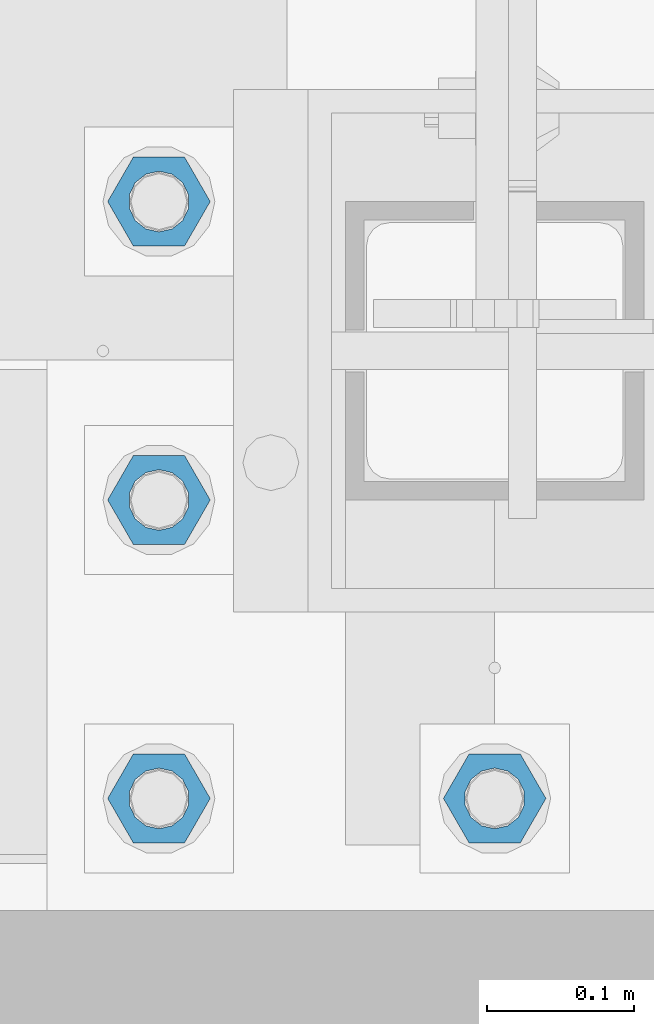
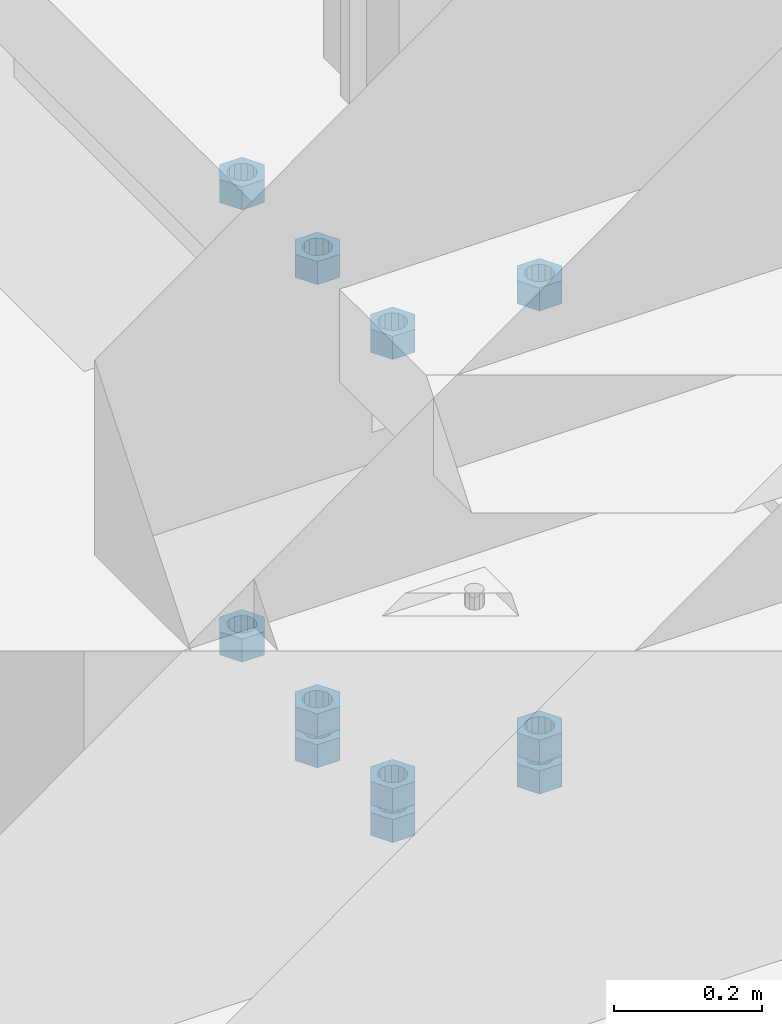
# One storey, part 978 of 1763: 11 columns, 1 element without a shape of its own.
"""IFC2X3 building model written with IfcOpenShell, lengths in millimetres."""

from ifc_helpers import new_model, si_unit, frame, origin_with_axes, place, context, subcontext, project, spatial, faceted_brep, material, type_object, element, aggregate, save


model = new_model("IFC2X3")

# Units and contexts
model_context = context("Model", 3, precision=1e-05, world=origin_with_axes())
body_context = subcontext(model_context, "Body", "Model", "MODEL_VIEW")
ifc_project = project(units=[si_unit("LENGTHUNIT", "METRE", prefix="MILLI"), si_unit("AREAUNIT", "SQUARE_METRE"), si_unit("VOLUMEUNIT", "CUBIC_METRE"), si_unit("MASSUNIT", "GRAM", prefix="KILO"), si_unit("TIMEUNIT", "SECOND"), si_unit("PLANEANGLEUNIT", "RADIAN"), si_unit("SOLIDANGLEUNIT", "STERADIAN"), si_unit("THERMODYNAMICTEMPERATUREUNIT", "DEGREE_CELSIUS"), si_unit("LUMINOUSINTENSITYUNIT", "LUMEN")], contexts=[model_context])

# Site, building, storey
site_placement = place(None, origin_with_axes())
site = spatial("IfcSite", under=ifc_project, at=site_placement, CompositionType="ELEMENT")
building_placement = place(site_placement, origin_with_axes())
building = spatial("IfcBuilding", under=site, at=building_placement, Name="Undefined", CompositionType="ELEMENT")
storey_placement = place(building_placement, origin_with_axes())
storey = spatial("IfcBuildingStorey", under=building, at=storey_placement, Name="Undefined", CompositionType="ELEMENT", Elevation=0.0)

# Assembly, columns
assembly_placement = place(storey_placement, origin_with_axes())
assembly = element("IfcElementAssembly", 1, at=assembly_placement, inside=storey, Name="TEMPLATE", AssemblyPlace="NOTDEFINED", PredefinedType="RIGID_FRAME")
ifc_material = material(Name="STEEL/A563")
column_type = type_object("IfcColumnType", Name="1-1/2_HEAVY_HEX_NUT", PredefinedType="NOTDEFINED")
column_1_placement = place(assembly_placement, frame((-87604.0372736983, -14020.8, 5189.53750000001), z_axis=(0.0, -1.0, 0.0), x_axis=(0.0, 0.0, -1.0)))
column_1 = element("IfcColumn", 2, at=column_1_placement, type_object=column_type, material=ifc_material, Name="NUT", ObjectType="1-1/2_HEAVY_HEX_NUT", context=body_context, shape_type="Brep", body=[
    faceted_brep([(0.0, -34.9199981689453, 0.0), (0.0, -17.4599990844727, -30.25), (38.1000000000004, -17.4599990844727, -30.25), (38.1000000000004, -34.9199981689453, 0.0), (0.0, 17.4599990844727, -30.25), (38.1000000000004, 17.4599990844727, -30.25), (0.0, 34.9199981689453, 0.0), (38.1000000000004, 34.9199981689453, 0.0), (0.0, 17.4599990844727, 30.25), (38.1000000000004, 17.4599990844727, 30.25), (0.0, -17.4599990844727, 30.25), (38.1000000000004, -17.4599990844727, 30.25), (0.0, 0.0, 20.6399993896484), (0.0, 8.95536011056538, 18.5959968835978), (38.1000000000004, 8.95536011056538, 18.5959968835978), (38.1000000000004, 0.0, 20.6399993896484), (0.0, 16.1370013209453, 12.8688291298167), (38.1000000000004, 16.1370013209453, 12.8688291298167), (0.0, 20.1225115123816, 4.59283194104137), (38.1000000000004, 20.1225115123816, 4.59283194104137), (0.0, 20.1225115123816, -4.59283194104319), (38.1000000000004, 20.1225115123816, -4.59283194104319), (0.0, 16.1370013209453, -12.8688291298167), (38.1000000000004, 16.1370013209453, -12.8688291298167), (0.0, 8.95536011056538, -18.5959968835978), (38.1000000000004, 8.95536011056538, -18.5959968835978), (0.0, 0.0, -20.6399993896484), (38.1000000000004, 0.0, -20.6399993896484), (0.0, -8.95536011056538, -18.5959968835978), (38.1000000000004, -8.95536011056538, -18.5959968835978), (0.0, -16.1370013209453, -12.8688291298167), (38.1000000000004, -16.1370013209453, -12.8688291298167), (0.0, -20.1225115123816, -4.59283194104137), (38.1000000000004, -20.1225115123816, -4.59283194104137), (0.0, -20.1225115123816, 4.59283194104319), (38.1000000000004, -20.1225115123816, 4.59283194104319), (0.0, -16.1370013209453, 12.8688291298167), (38.1000000000004, -16.1370013209453, 12.8688291298167), (0.0, -8.95536011056538, 18.5959968835978), (38.1000000000004, -8.95536011056538, 18.5959968835978)], [[[0, 1, 2, 3]], [[1, 4, 5, 2]], [[4, 6, 7, 5]], [[6, 8, 9, 7]], [[8, 10, 11, 9]], [[10, 0, 3, 11]], [[12, 13, 14, 15]], [[13, 16, 17, 14]], [[16, 18, 19, 17]], [[18, 20, 21, 19]], [[20, 22, 23, 21]], [[22, 24, 25, 23]], [[24, 26, 27, 25]], [[26, 28, 29, 27]], [[28, 30, 31, 29]], [[30, 32, 33, 31]], [[32, 34, 35, 33]], [[34, 36, 37, 35]], [[36, 38, 39, 37]], [[38, 12, 15, 39]], [[5, 7, 9, 11, 3, 2], [17, 19, 21, 23, 25, 27, 29, 31, 33, 35, 37, 39, 15, 14]], [[10, 8, 6, 4, 1, 0], [38, 36, 34, 32, 30, 28, 26, 24, 22, 20, 18, 16, 13, 12]]]),
])
column_2_placement = place(assembly_placement, frame((-87604.0372736983, -14020.8, 4445.00000000001), z_axis=(0.0, -1.0, 0.0), x_axis=(0.0, 0.0, -1.0)))
column_2 = element("IfcColumn", 3, at=column_2_placement, type_object=column_type, material=ifc_material, Name="NUT", ObjectType="1-1/2_HEAVY_HEX_NUT", context=body_context, shape_type="Brep", body=[
    faceted_brep([(0.0, -34.9199981689453, 0.0), (0.0, -17.4599990844727, -30.25), (38.1000000000004, -17.4599990844727, -30.25), (38.1000000000004, -34.9199981689453, 0.0), (0.0, 17.4599990844727, -30.25), (38.1000000000004, 17.4599990844727, -30.25), (0.0, 34.9199981689453, 0.0), (38.1000000000004, 34.9199981689453, 0.0), (0.0, 17.4599990844727, 30.25), (38.1000000000004, 17.4599990844727, 30.25), (0.0, -17.4599990844727, 30.25), (38.1000000000004, -17.4599990844727, 30.25), (0.0, 0.0, 20.6399993896484), (0.0, 8.95536011056538, 18.5959968835978), (38.1000000000004, 8.95536011056538, 18.5959968835978), (38.1000000000004, 0.0, 20.6399993896484), (0.0, 16.1370013209453, 12.8688291298167), (38.1000000000004, 16.1370013209453, 12.8688291298167), (0.0, 20.1225115123816, 4.59283194104137), (38.1000000000004, 20.1225115123816, 4.59283194104137), (0.0, 20.1225115123816, -4.59283194104319), (38.1000000000004, 20.1225115123816, -4.59283194104319), (0.0, 16.1370013209453, -12.8688291298167), (38.1000000000004, 16.1370013209453, -12.8688291298167), (0.0, 8.95536011056538, -18.5959968835978), (38.1000000000004, 8.95536011056538, -18.5959968835978), (0.0, 0.0, -20.6399993896484), (38.1000000000004, 0.0, -20.6399993896484), (0.0, -8.95536011056538, -18.5959968835978), (38.1000000000004, -8.95536011056538, -18.5959968835978), (0.0, -16.1370013209453, -12.8688291298167), (38.1000000000004, -16.1370013209453, -12.8688291298167), (0.0, -20.1225115123816, -4.59283194104137), (38.1000000000004, -20.1225115123816, -4.59283194104137), (0.0, -20.1225115123816, 4.59283194104319), (38.1000000000004, -20.1225115123816, 4.59283194104319), (0.0, -16.1370013209453, 12.8688291298167), (38.1000000000004, -16.1370013209453, 12.8688291298167), (0.0, -8.95536011056538, 18.5959968835978), (38.1000000000004, -8.95536011056538, 18.5959968835978)], [[[0, 1, 2, 3]], [[1, 4, 5, 2]], [[4, 6, 7, 5]], [[6, 8, 9, 7]], [[8, 10, 11, 9]], [[10, 0, 3, 11]], [[12, 13, 14, 15]], [[13, 16, 17, 14]], [[16, 18, 19, 17]], [[18, 20, 21, 19]], [[20, 22, 23, 21]], [[22, 24, 25, 23]], [[24, 26, 27, 25]], [[26, 28, 29, 27]], [[28, 30, 31, 29]], [[30, 32, 33, 31]], [[32, 34, 35, 33]], [[34, 36, 37, 35]], [[36, 38, 39, 37]], [[38, 12, 15, 39]], [[5, 7, 9, 11, 3, 2], [17, 19, 21, 23, 25, 27, 29, 31, 33, 35, 37, 39, 15, 14]], [[10, 8, 6, 4, 1, 0], [38, 36, 34, 32, 30, 28, 26, 24, 22, 20, 18, 16, 13, 12]]]),
])
column_3_placement = place(assembly_placement, frame((-87604.0372736983, -14020.8, 4394.20000000001), z_axis=(0.0, -1.0, 0.0), x_axis=(0.0, 0.0, -1.0)))
column_3 = element("IfcColumn", 4, at=column_3_placement, type_object=column_type, material=ifc_material, Name="NUT", ObjectType="1-1/2_HEAVY_HEX_NUT", context=body_context, shape_type="Brep", body=[
    faceted_brep([(0.0, -34.9199981689453, 0.0), (0.0, -17.4599990844727, -30.25), (38.1000000000004, -17.4599990844727, -30.25), (38.1000000000004, -34.9199981689453, 0.0), (0.0, 17.4599990844727, -30.25), (38.1000000000004, 17.4599990844727, -30.25), (0.0, 34.9199981689453, 0.0), (38.1000000000004, 34.9199981689453, 0.0), (0.0, 17.4599990844727, 30.25), (38.1000000000004, 17.4599990844727, 30.25), (0.0, -17.4599990844727, 30.25), (38.1000000000004, -17.4599990844727, 30.25), (0.0, 0.0, 20.6399993896484), (0.0, 8.95536011056538, 18.5959968835978), (38.1000000000004, 8.95536011056538, 18.5959968835978), (38.1000000000004, 0.0, 20.6399993896484), (0.0, 16.1370013209453, 12.8688291298167), (38.1000000000004, 16.1370013209453, 12.8688291298167), (0.0, 20.1225115123816, 4.59283194104137), (38.1000000000004, 20.1225115123816, 4.59283194104137), (0.0, 20.1225115123816, -4.59283194104319), (38.1000000000004, 20.1225115123816, -4.59283194104319), (0.0, 16.1370013209453, -12.8688291298167), (38.1000000000004, 16.1370013209453, -12.8688291298167), (0.0, 8.95536011056538, -18.5959968835978), (38.1000000000004, 8.95536011056538, -18.5959968835978), (0.0, 0.0, -20.6399993896484), (38.1000000000004, 0.0, -20.6399993896484), (0.0, -8.95536011056538, -18.5959968835978), (38.1000000000004, -8.95536011056538, -18.5959968835978), (0.0, -16.1370013209453, -12.8688291298167), (38.1000000000004, -16.1370013209453, -12.8688291298167), (0.0, -20.1225115123816, -4.59283194104137), (38.1000000000004, -20.1225115123816, -4.59283194104137), (0.0, -20.1225115123816, 4.59283194104319), (38.1000000000004, -20.1225115123816, 4.59283194104319), (0.0, -16.1370013209453, 12.8688291298167), (38.1000000000004, -16.1370013209453, 12.8688291298167), (0.0, -8.95536011056538, 18.5959968835978), (38.1000000000004, -8.95536011056538, 18.5959968835978)], [[[0, 1, 2, 3]], [[1, 4, 5, 2]], [[4, 6, 7, 5]], [[6, 8, 9, 7]], [[8, 10, 11, 9]], [[10, 0, 3, 11]], [[12, 13, 14, 15]], [[13, 16, 17, 14]], [[16, 18, 19, 17]], [[18, 20, 21, 19]], [[20, 22, 23, 21]], [[22, 24, 25, 23]], [[24, 26, 27, 25]], [[26, 28, 29, 27]], [[28, 30, 31, 29]], [[30, 32, 33, 31]], [[32, 34, 35, 33]], [[34, 36, 37, 35]], [[36, 38, 39, 37]], [[38, 12, 15, 39]], [[5, 7, 9, 11, 3, 2], [17, 19, 21, 23, 25, 27, 29, 31, 33, 35, 37, 39, 15, 14]], [[10, 8, 6, 4, 1, 0], [38, 36, 34, 32, 30, 28, 26, 24, 22, 20, 18, 16, 13, 12]]]),
])
column_4_placement = place(assembly_placement, frame((-87375.4372736983, -14020.8, 5189.53750000001), z_axis=(0.0, -1.0, 0.0), x_axis=(0.0, 0.0, -1.0)))
column_4 = element("IfcColumn", 5, at=column_4_placement, type_object=column_type, material=ifc_material, Name="NUT", ObjectType="1-1/2_HEAVY_HEX_NUT", context=body_context, shape_type="Brep", body=[
    faceted_brep([(0.0, -34.9199981689453, 0.0), (0.0, -17.4599990844727, -30.25), (38.1000000000004, -17.4599990844727, -30.25), (38.1000000000004, -34.9199981689453, 0.0), (0.0, 17.4599990844727, -30.25), (38.1000000000004, 17.4599990844727, -30.25), (0.0, 34.9199981689453, 0.0), (38.1000000000004, 34.9199981689453, 0.0), (0.0, 17.4599990844727, 30.25), (38.1000000000004, 17.4599990844727, 30.25), (0.0, -17.4599990844727, 30.25), (38.1000000000004, -17.4599990844727, 30.25), (0.0, 0.0, 20.6399993896484), (0.0, 8.95536011056538, 18.5959968835978), (38.1000000000004, 8.95536011056538, 18.5959968835978), (38.1000000000004, 0.0, 20.6399993896484), (0.0, 16.1370013209453, 12.8688291298167), (38.1000000000004, 16.1370013209453, 12.8688291298167), (0.0, 20.1225115123816, 4.59283194104137), (38.1000000000004, 20.1225115123816, 4.59283194104137), (0.0, 20.1225115123816, -4.59283194104319), (38.1000000000004, 20.1225115123816, -4.59283194104319), (0.0, 16.1370013209453, -12.8688291298167), (38.1000000000004, 16.1370013209453, -12.8688291298167), (0.0, 8.95536011056538, -18.5959968835978), (38.1000000000004, 8.95536011056538, -18.5959968835978), (0.0, 0.0, -20.6399993896484), (38.1000000000004, 0.0, -20.6399993896484), (0.0, -8.95536011056538, -18.5959968835978), (38.1000000000004, -8.95536011056538, -18.5959968835978), (0.0, -16.1370013209453, -12.8688291298167), (38.1000000000004, -16.1370013209453, -12.8688291298167), (0.0, -20.1225115123816, -4.59283194104137), (38.1000000000004, -20.1225115123816, -4.59283194104137), (0.0, -20.1225115123816, 4.59283194104319), (38.1000000000004, -20.1225115123816, 4.59283194104319), (0.0, -16.1370013209453, 12.8688291298167), (38.1000000000004, -16.1370013209453, 12.8688291298167), (0.0, -8.95536011056538, 18.5959968835978), (38.1000000000004, -8.95536011056538, 18.5959968835978)], [[[0, 1, 2, 3]], [[1, 4, 5, 2]], [[4, 6, 7, 5]], [[6, 8, 9, 7]], [[8, 10, 11, 9]], [[10, 0, 3, 11]], [[12, 13, 14, 15]], [[13, 16, 17, 14]], [[16, 18, 19, 17]], [[18, 20, 21, 19]], [[20, 22, 23, 21]], [[22, 24, 25, 23]], [[24, 26, 27, 25]], [[26, 28, 29, 27]], [[28, 30, 31, 29]], [[30, 32, 33, 31]], [[32, 34, 35, 33]], [[34, 36, 37, 35]], [[36, 38, 39, 37]], [[38, 12, 15, 39]], [[5, 7, 9, 11, 3, 2], [17, 19, 21, 23, 25, 27, 29, 31, 33, 35, 37, 39, 15, 14]], [[10, 8, 6, 4, 1, 0], [38, 36, 34, 32, 30, 28, 26, 24, 22, 20, 18, 16, 13, 12]]]),
])
column_5_placement = place(assembly_placement, frame((-87375.4372736983, -14020.8, 4445.00000000001), z_axis=(0.0, -1.0, 0.0), x_axis=(0.0, 0.0, -1.0)))
column_5 = element("IfcColumn", 6, at=column_5_placement, type_object=column_type, material=ifc_material, Name="NUT", ObjectType="1-1/2_HEAVY_HEX_NUT", context=body_context, shape_type="Brep", body=[
    faceted_brep([(0.0, -34.9199981689453, 0.0), (0.0, -17.4599990844727, -30.25), (38.1000000000004, -17.4599990844727, -30.25), (38.1000000000004, -34.9199981689453, 0.0), (0.0, 17.4599990844727, -30.25), (38.1000000000004, 17.4599990844727, -30.25), (0.0, 34.9199981689453, 0.0), (38.1000000000004, 34.9199981689453, 0.0), (0.0, 17.4599990844727, 30.25), (38.1000000000004, 17.4599990844727, 30.25), (0.0, -17.4599990844727, 30.25), (38.1000000000004, -17.4599990844727, 30.25), (0.0, 0.0, 20.6399993896484), (0.0, 8.95536011056538, 18.5959968835978), (38.1000000000004, 8.95536011056538, 18.5959968835978), (38.1000000000004, 0.0, 20.6399993896484), (0.0, 16.1370013209453, 12.8688291298167), (38.1000000000004, 16.1370013209453, 12.8688291298167), (0.0, 20.1225115123816, 4.59283194104137), (38.1000000000004, 20.1225115123816, 4.59283194104137), (0.0, 20.1225115123816, -4.59283194104319), (38.1000000000004, 20.1225115123816, -4.59283194104319), (0.0, 16.1370013209453, -12.8688291298167), (38.1000000000004, 16.1370013209453, -12.8688291298167), (0.0, 8.95536011056538, -18.5959968835978), (38.1000000000004, 8.95536011056538, -18.5959968835978), (0.0, 0.0, -20.6399993896484), (38.1000000000004, 0.0, -20.6399993896484), (0.0, -8.95536011056538, -18.5959968835978), (38.1000000000004, -8.95536011056538, -18.5959968835978), (0.0, -16.1370013209453, -12.8688291298167), (38.1000000000004, -16.1370013209453, -12.8688291298167), (0.0, -20.1225115123816, -4.59283194104137), (38.1000000000004, -20.1225115123816, -4.59283194104137), (0.0, -20.1225115123816, 4.59283194104319), (38.1000000000004, -20.1225115123816, 4.59283194104319), (0.0, -16.1370013209453, 12.8688291298167), (38.1000000000004, -16.1370013209453, 12.8688291298167), (0.0, -8.95536011056538, 18.5959968835978), (38.1000000000004, -8.95536011056538, 18.5959968835978)], [[[0, 1, 2, 3]], [[1, 4, 5, 2]], [[4, 6, 7, 5]], [[6, 8, 9, 7]], [[8, 10, 11, 9]], [[10, 0, 3, 11]], [[12, 13, 14, 15]], [[13, 16, 17, 14]], [[16, 18, 19, 17]], [[18, 20, 21, 19]], [[20, 22, 23, 21]], [[22, 24, 25, 23]], [[24, 26, 27, 25]], [[26, 28, 29, 27]], [[28, 30, 31, 29]], [[30, 32, 33, 31]], [[32, 34, 35, 33]], [[34, 36, 37, 35]], [[36, 38, 39, 37]], [[38, 12, 15, 39]], [[5, 7, 9, 11, 3, 2], [17, 19, 21, 23, 25, 27, 29, 31, 33, 35, 37, 39, 15, 14]], [[10, 8, 6, 4, 1, 0], [38, 36, 34, 32, 30, 28, 26, 24, 22, 20, 18, 16, 13, 12]]]),
])
column_6_placement = place(assembly_placement, frame((-87375.4372736983, -14020.8, 4394.20000000001), z_axis=(0.0, -1.0, 0.0), x_axis=(0.0, 0.0, -1.0)))
column_6 = element("IfcColumn", 7, at=column_6_placement, type_object=column_type, material=ifc_material, Name="NUT", ObjectType="1-1/2_HEAVY_HEX_NUT", context=body_context, shape_type="Brep", body=[
    faceted_brep([(0.0, -34.9199981689453, 0.0), (0.0, -17.4599990844727, -30.25), (38.1000000000004, -17.4599990844727, -30.25), (38.1000000000004, -34.9199981689453, 0.0), (0.0, 17.4599990844727, -30.25), (38.1000000000004, 17.4599990844727, -30.25), (0.0, 34.9199981689453, 0.0), (38.1000000000004, 34.9199981689453, 0.0), (0.0, 17.4599990844727, 30.25), (38.1000000000004, 17.4599990844727, 30.25), (0.0, -17.4599990844727, 30.25), (38.1000000000004, -17.4599990844727, 30.25), (0.0, 0.0, 20.6399993896484), (0.0, 8.95536011056538, 18.5959968835978), (38.1000000000004, 8.95536011056538, 18.5959968835978), (38.1000000000004, 0.0, 20.6399993896484), (0.0, 16.1370013209453, 12.8688291298167), (38.1000000000004, 16.1370013209453, 12.8688291298167), (0.0, 20.1225115123816, 4.59283194104137), (38.1000000000004, 20.1225115123816, 4.59283194104137), (0.0, 20.1225115123816, -4.59283194104319), (38.1000000000004, 20.1225115123816, -4.59283194104319), (0.0, 16.1370013209453, -12.8688291298167), (38.1000000000004, 16.1370013209453, -12.8688291298167), (0.0, 8.95536011056538, -18.5959968835978), (38.1000000000004, 8.95536011056538, -18.5959968835978), (0.0, 0.0, -20.6399993896484), (38.1000000000004, 0.0, -20.6399993896484), (0.0, -8.95536011056538, -18.5959968835978), (38.1000000000004, -8.95536011056538, -18.5959968835978), (0.0, -16.1370013209453, -12.8688291298167), (38.1000000000004, -16.1370013209453, -12.8688291298167), (0.0, -20.1225115123816, -4.59283194104137), (38.1000000000004, -20.1225115123816, -4.59283194104137), (0.0, -20.1225115123816, 4.59283194104319), (38.1000000000004, -20.1225115123816, 4.59283194104319), (0.0, -16.1370013209453, 12.8688291298167), (38.1000000000004, -16.1370013209453, 12.8688291298167), (0.0, -8.95536011056538, 18.5959968835978), (38.1000000000004, -8.95536011056538, 18.5959968835978)], [[[0, 1, 2, 3]], [[1, 4, 5, 2]], [[4, 6, 7, 5]], [[6, 8, 9, 7]], [[8, 10, 11, 9]], [[10, 0, 3, 11]], [[12, 13, 14, 15]], [[13, 16, 17, 14]], [[16, 18, 19, 17]], [[18, 20, 21, 19]], [[20, 22, 23, 21]], [[22, 24, 25, 23]], [[24, 26, 27, 25]], [[26, 28, 29, 27]], [[28, 30, 31, 29]], [[30, 32, 33, 31]], [[32, 34, 35, 33]], [[34, 36, 37, 35]], [[36, 38, 39, 37]], [[38, 12, 15, 39]], [[5, 7, 9, 11, 3, 2], [17, 19, 21, 23, 25, 27, 29, 31, 33, 35, 37, 39, 15, 14]], [[10, 8, 6, 4, 1, 0], [38, 36, 34, 32, 30, 28, 26, 24, 22, 20, 18, 16, 13, 12]]]),
])
column_7_placement = place(assembly_placement, frame((-87604.0372736983, -13817.6, 5189.53750000001), z_axis=(0.0, -1.0, 0.0), x_axis=(0.0, 0.0, -1.0)))
column_7 = element("IfcColumn", 8, at=column_7_placement, type_object=column_type, material=ifc_material, Name="NUT", ObjectType="1-1/2_HEAVY_HEX_NUT", context=body_context, shape_type="Brep", body=[
    faceted_brep([(0.0, -34.9199981689453, 0.0), (0.0, -17.4599990844727, -30.25), (38.1000000000004, -17.4599990844727, -30.25), (38.1000000000004, -34.9199981689453, 0.0), (0.0, 17.4599990844727, -30.25), (38.1000000000004, 17.4599990844727, -30.25), (0.0, 34.9199981689453, 0.0), (38.1000000000004, 34.9199981689453, 0.0), (0.0, 17.4599990844727, 30.25), (38.1000000000004, 17.4599990844727, 30.25), (0.0, -17.4599990844727, 30.25), (38.1000000000004, -17.4599990844727, 30.25), (0.0, 0.0, 20.6399993896484), (0.0, 8.95536011056538, 18.5959968835978), (38.1000000000004, 8.95536011056538, 18.5959968835978), (38.1000000000004, 0.0, 20.6399993896484), (0.0, 16.1370013209453, 12.8688291298167), (38.1000000000004, 16.1370013209453, 12.8688291298167), (0.0, 20.1225115123816, 4.59283194104137), (38.1000000000004, 20.1225115123816, 4.59283194104137), (0.0, 20.1225115123816, -4.59283194104319), (38.1000000000004, 20.1225115123816, -4.59283194104319), (0.0, 16.1370013209453, -12.8688291298167), (38.1000000000004, 16.1370013209453, -12.8688291298167), (0.0, 8.95536011056538, -18.5959968835978), (38.1000000000004, 8.95536011056538, -18.5959968835978), (0.0, 0.0, -20.6399993896484), (38.1000000000004, 0.0, -20.6399993896484), (0.0, -8.95536011056538, -18.5959968835978), (38.1000000000004, -8.95536011056538, -18.5959968835978), (0.0, -16.1370013209453, -12.8688291298167), (38.1000000000004, -16.1370013209453, -12.8688291298167), (0.0, -20.1225115123816, -4.59283194104137), (38.1000000000004, -20.1225115123816, -4.59283194104137), (0.0, -20.1225115123816, 4.59283194104319), (38.1000000000004, -20.1225115123816, 4.59283194104319), (0.0, -16.1370013209453, 12.8688291298167), (38.1000000000004, -16.1370013209453, 12.8688291298167), (0.0, -8.95536011056538, 18.5959968835978), (38.1000000000004, -8.95536011056538, 18.5959968835978)], [[[0, 1, 2, 3]], [[1, 4, 5, 2]], [[4, 6, 7, 5]], [[6, 8, 9, 7]], [[8, 10, 11, 9]], [[10, 0, 3, 11]], [[12, 13, 14, 15]], [[13, 16, 17, 14]], [[16, 18, 19, 17]], [[18, 20, 21, 19]], [[20, 22, 23, 21]], [[22, 24, 25, 23]], [[24, 26, 27, 25]], [[26, 28, 29, 27]], [[28, 30, 31, 29]], [[30, 32, 33, 31]], [[32, 34, 35, 33]], [[34, 36, 37, 35]], [[36, 38, 39, 37]], [[38, 12, 15, 39]], [[5, 7, 9, 11, 3, 2], [17, 19, 21, 23, 25, 27, 29, 31, 33, 35, 37, 39, 15, 14]], [[10, 8, 6, 4, 1, 0], [38, 36, 34, 32, 30, 28, 26, 24, 22, 20, 18, 16, 13, 12]]]),
])
column_8_placement = place(assembly_placement, frame((-87604.0372736983, -13817.6, 4445.00000000001), z_axis=(0.0, -1.0, 0.0), x_axis=(0.0, 0.0, -1.0)))
column_8 = element("IfcColumn", 9, at=column_8_placement, type_object=column_type, material=ifc_material, Name="NUT", ObjectType="1-1/2_HEAVY_HEX_NUT", context=body_context, shape_type="Brep", body=[
    faceted_brep([(0.0, -34.9199981689453, 0.0), (0.0, -17.4599990844727, -30.25), (38.1000000000004, -17.4599990844727, -30.25), (38.1000000000004, -34.9199981689453, 0.0), (0.0, 17.4599990844727, -30.25), (38.1000000000004, 17.4599990844727, -30.25), (0.0, 34.9199981689453, 0.0), (38.1000000000004, 34.9199981689453, 0.0), (0.0, 17.4599990844727, 30.25), (38.1000000000004, 17.4599990844727, 30.25), (0.0, -17.4599990844727, 30.25), (38.1000000000004, -17.4599990844727, 30.25), (0.0, 0.0, 20.6399993896484), (0.0, 8.95536011056538, 18.5959968835978), (38.1000000000004, 8.95536011056538, 18.5959968835978), (38.1000000000004, 0.0, 20.6399993896484), (0.0, 16.1370013209453, 12.8688291298167), (38.1000000000004, 16.1370013209453, 12.8688291298167), (0.0, 20.1225115123816, 4.59283194104137), (38.1000000000004, 20.1225115123816, 4.59283194104137), (0.0, 20.1225115123816, -4.59283194104319), (38.1000000000004, 20.1225115123816, -4.59283194104319), (0.0, 16.1370013209453, -12.8688291298167), (38.1000000000004, 16.1370013209453, -12.8688291298167), (0.0, 8.95536011056538, -18.5959968835978), (38.1000000000004, 8.95536011056538, -18.5959968835978), (0.0, 0.0, -20.6399993896484), (38.1000000000004, 0.0, -20.6399993896484), (0.0, -8.95536011056538, -18.5959968835978), (38.1000000000004, -8.95536011056538, -18.5959968835978), (0.0, -16.1370013209453, -12.8688291298167), (38.1000000000004, -16.1370013209453, -12.8688291298167), (0.0, -20.1225115123816, -4.59283194104137), (38.1000000000004, -20.1225115123816, -4.59283194104137), (0.0, -20.1225115123816, 4.59283194104319), (38.1000000000004, -20.1225115123816, 4.59283194104319), (0.0, -16.1370013209453, 12.8688291298167), (38.1000000000004, -16.1370013209453, 12.8688291298167), (0.0, -8.95536011056538, 18.5959968835978), (38.1000000000004, -8.95536011056538, 18.5959968835978)], [[[0, 1, 2, 3]], [[1, 4, 5, 2]], [[4, 6, 7, 5]], [[6, 8, 9, 7]], [[8, 10, 11, 9]], [[10, 0, 3, 11]], [[12, 13, 14, 15]], [[13, 16, 17, 14]], [[16, 18, 19, 17]], [[18, 20, 21, 19]], [[20, 22, 23, 21]], [[22, 24, 25, 23]], [[24, 26, 27, 25]], [[26, 28, 29, 27]], [[28, 30, 31, 29]], [[30, 32, 33, 31]], [[32, 34, 35, 33]], [[34, 36, 37, 35]], [[36, 38, 39, 37]], [[38, 12, 15, 39]], [[5, 7, 9, 11, 3, 2], [17, 19, 21, 23, 25, 27, 29, 31, 33, 35, 37, 39, 15, 14]], [[10, 8, 6, 4, 1, 0], [38, 36, 34, 32, 30, 28, 26, 24, 22, 20, 18, 16, 13, 12]]]),
])
column_9_placement = place(assembly_placement, frame((-87604.0372736983, -13817.6, 4394.20000000001), z_axis=(0.0, -1.0, 0.0), x_axis=(0.0, 0.0, -1.0)))
column_9 = element("IfcColumn", 10, at=column_9_placement, type_object=column_type, material=ifc_material, Name="NUT", ObjectType="1-1/2_HEAVY_HEX_NUT", context=body_context, shape_type="Brep", body=[
    faceted_brep([(0.0, -34.9199981689453, 0.0), (0.0, -17.4599990844727, -30.25), (38.1000000000004, -17.4599990844727, -30.25), (38.1000000000004, -34.9199981689453, 0.0), (0.0, 17.4599990844727, -30.25), (38.1000000000004, 17.4599990844727, -30.25), (0.0, 34.9199981689453, 0.0), (38.1000000000004, 34.9199981689453, 0.0), (0.0, 17.4599990844727, 30.25), (38.1000000000004, 17.4599990844727, 30.25), (0.0, -17.4599990844727, 30.25), (38.1000000000004, -17.4599990844727, 30.25), (0.0, 0.0, 20.6399993896484), (0.0, 8.95536011056538, 18.5959968835978), (38.1000000000004, 8.95536011056538, 18.5959968835978), (38.1000000000004, 0.0, 20.6399993896484), (0.0, 16.1370013209453, 12.8688291298167), (38.1000000000004, 16.1370013209453, 12.8688291298167), (0.0, 20.1225115123816, 4.59283194104137), (38.1000000000004, 20.1225115123816, 4.59283194104137), (0.0, 20.1225115123816, -4.59283194104319), (38.1000000000004, 20.1225115123816, -4.59283194104319), (0.0, 16.1370013209453, -12.8688291298167), (38.1000000000004, 16.1370013209453, -12.8688291298167), (0.0, 8.95536011056538, -18.5959968835978), (38.1000000000004, 8.95536011056538, -18.5959968835978), (0.0, 0.0, -20.6399993896484), (38.1000000000004, 0.0, -20.6399993896484), (0.0, -8.95536011056538, -18.5959968835978), (38.1000000000004, -8.95536011056538, -18.5959968835978), (0.0, -16.1370013209453, -12.8688291298167), (38.1000000000004, -16.1370013209453, -12.8688291298167), (0.0, -20.1225115123816, -4.59283194104137), (38.1000000000004, -20.1225115123816, -4.59283194104137), (0.0, -20.1225115123816, 4.59283194104319), (38.1000000000004, -20.1225115123816, 4.59283194104319), (0.0, -16.1370013209453, 12.8688291298167), (38.1000000000004, -16.1370013209453, 12.8688291298167), (0.0, -8.95536011056538, 18.5959968835978), (38.1000000000004, -8.95536011056538, 18.5959968835978)], [[[0, 1, 2, 3]], [[1, 4, 5, 2]], [[4, 6, 7, 5]], [[6, 8, 9, 7]], [[8, 10, 11, 9]], [[10, 0, 3, 11]], [[12, 13, 14, 15]], [[13, 16, 17, 14]], [[16, 18, 19, 17]], [[18, 20, 21, 19]], [[20, 22, 23, 21]], [[22, 24, 25, 23]], [[24, 26, 27, 25]], [[26, 28, 29, 27]], [[28, 30, 31, 29]], [[30, 32, 33, 31]], [[32, 34, 35, 33]], [[34, 36, 37, 35]], [[36, 38, 39, 37]], [[38, 12, 15, 39]], [[5, 7, 9, 11, 3, 2], [17, 19, 21, 23, 25, 27, 29, 31, 33, 35, 37, 39, 15, 14]], [[10, 8, 6, 4, 1, 0], [38, 36, 34, 32, 30, 28, 26, 24, 22, 20, 18, 16, 13, 12]]]),
])
column_10_placement = place(assembly_placement, frame((-87604.0372736983, -13614.4, 5189.53750000001), z_axis=(0.0, -1.0, 0.0), x_axis=(0.0, 0.0, -1.0)))
column_10 = element("IfcColumn", 11, at=column_10_placement, type_object=column_type, material=ifc_material, Name="NUT", ObjectType="1-1/2_HEAVY_HEX_NUT", context=body_context, shape_type="Brep", body=[
    faceted_brep([(0.0, -34.9199981689453, 0.0), (0.0, -17.4599990844727, -30.25), (38.1000000000004, -17.4599990844727, -30.25), (38.1000000000004, -34.9199981689453, 0.0), (0.0, 17.4599990844727, -30.25), (38.1000000000004, 17.4599990844727, -30.25), (0.0, 34.9199981689453, 0.0), (38.1000000000004, 34.9199981689453, 0.0), (0.0, 17.4599990844727, 30.25), (38.1000000000004, 17.4599990844727, 30.25), (0.0, -17.4599990844727, 30.25), (38.1000000000004, -17.4599990844727, 30.25), (0.0, 0.0, 20.6399993896484), (0.0, 8.95536011056538, 18.5959968835978), (38.1000000000004, 8.95536011056538, 18.5959968835978), (38.1000000000004, 0.0, 20.6399993896484), (0.0, 16.1370013209453, 12.8688291298167), (38.1000000000004, 16.1370013209453, 12.8688291298167), (0.0, 20.1225115123816, 4.59283194104137), (38.1000000000004, 20.1225115123816, 4.59283194104137), (0.0, 20.1225115123816, -4.59283194104319), (38.1000000000004, 20.1225115123816, -4.59283194104319), (0.0, 16.1370013209453, -12.8688291298167), (38.1000000000004, 16.1370013209453, -12.8688291298167), (0.0, 8.95536011056538, -18.5959968835978), (38.1000000000004, 8.95536011056538, -18.5959968835978), (0.0, 0.0, -20.6399993896484), (38.1000000000004, 0.0, -20.6399993896484), (0.0, -8.95536011056538, -18.5959968835978), (38.1000000000004, -8.95536011056538, -18.5959968835978), (0.0, -16.1370013209453, -12.8688291298167), (38.1000000000004, -16.1370013209453, -12.8688291298167), (0.0, -20.1225115123816, -4.59283194104137), (38.1000000000004, -20.1225115123816, -4.59283194104137), (0.0, -20.1225115123816, 4.59283194104319), (38.1000000000004, -20.1225115123816, 4.59283194104319), (0.0, -16.1370013209453, 12.8688291298167), (38.1000000000004, -16.1370013209453, 12.8688291298167), (0.0, -8.95536011056538, 18.5959968835978), (38.1000000000004, -8.95536011056538, 18.5959968835978)], [[[0, 1, 2, 3]], [[1, 4, 5, 2]], [[4, 6, 7, 5]], [[6, 8, 9, 7]], [[8, 10, 11, 9]], [[10, 0, 3, 11]], [[12, 13, 14, 15]], [[13, 16, 17, 14]], [[16, 18, 19, 17]], [[18, 20, 21, 19]], [[20, 22, 23, 21]], [[22, 24, 25, 23]], [[24, 26, 27, 25]], [[26, 28, 29, 27]], [[28, 30, 31, 29]], [[30, 32, 33, 31]], [[32, 34, 35, 33]], [[34, 36, 37, 35]], [[36, 38, 39, 37]], [[38, 12, 15, 39]], [[5, 7, 9, 11, 3, 2], [17, 19, 21, 23, 25, 27, 29, 31, 33, 35, 37, 39, 15, 14]], [[10, 8, 6, 4, 1, 0], [38, 36, 34, 32, 30, 28, 26, 24, 22, 20, 18, 16, 13, 12]]]),
])
column_11_placement = place(assembly_placement, frame((-87604.0372736983, -13614.4, 4445.00000000001), z_axis=(0.0, -1.0, 0.0), x_axis=(0.0, 0.0, -1.0)))
column_11 = element("IfcColumn", 12, at=column_11_placement, type_object=column_type, material=ifc_material, Name="NUT", ObjectType="1-1/2_HEAVY_HEX_NUT", context=body_context, shape_type="Brep", body=[
    faceted_brep([(0.0, -34.9199981689453, 0.0), (0.0, -17.4599990844727, -30.25), (38.1000000000004, -17.4599990844727, -30.25), (38.1000000000004, -34.9199981689453, 0.0), (0.0, 17.4599990844727, -30.25), (38.1000000000004, 17.4599990844727, -30.25), (0.0, 34.9199981689453, 0.0), (38.1000000000004, 34.9199981689453, 0.0), (0.0, 17.4599990844727, 30.25), (38.1000000000004, 17.4599990844727, 30.25), (0.0, -17.4599990844727, 30.25), (38.1000000000004, -17.4599990844727, 30.25), (0.0, 0.0, 20.6399993896484), (0.0, 8.95536011056538, 18.5959968835978), (38.1000000000004, 8.95536011056538, 18.5959968835978), (38.1000000000004, 0.0, 20.6399993896484), (0.0, 16.1370013209453, 12.8688291298167), (38.1000000000004, 16.1370013209453, 12.8688291298167), (0.0, 20.1225115123816, 4.59283194104137), (38.1000000000004, 20.1225115123816, 4.59283194104137), (0.0, 20.1225115123816, -4.59283194104319), (38.1000000000004, 20.1225115123816, -4.59283194104319), (0.0, 16.1370013209453, -12.8688291298167), (38.1000000000004, 16.1370013209453, -12.8688291298167), (0.0, 8.95536011056538, -18.5959968835978), (38.1000000000004, 8.95536011056538, -18.5959968835978), (0.0, 0.0, -20.6399993896484), (38.1000000000004, 0.0, -20.6399993896484), (0.0, -8.95536011056538, -18.5959968835978), (38.1000000000004, -8.95536011056538, -18.5959968835978), (0.0, -16.1370013209453, -12.8688291298167), (38.1000000000004, -16.1370013209453, -12.8688291298167), (0.0, -20.1225115123816, -4.59283194104137), (38.1000000000004, -20.1225115123816, -4.59283194104137), (0.0, -20.1225115123816, 4.59283194104319), (38.1000000000004, -20.1225115123816, 4.59283194104319), (0.0, -16.1370013209453, 12.8688291298167), (38.1000000000004, -16.1370013209453, 12.8688291298167), (0.0, -8.95536011056538, 18.5959968835978), (38.1000000000004, -8.95536011056538, 18.5959968835978)], [[[0, 1, 2, 3]], [[1, 4, 5, 2]], [[4, 6, 7, 5]], [[6, 8, 9, 7]], [[8, 10, 11, 9]], [[10, 0, 3, 11]], [[12, 13, 14, 15]], [[13, 16, 17, 14]], [[16, 18, 19, 17]], [[18, 20, 21, 19]], [[20, 22, 23, 21]], [[22, 24, 25, 23]], [[24, 26, 27, 25]], [[26, 28, 29, 27]], [[28, 30, 31, 29]], [[30, 32, 33, 31]], [[32, 34, 35, 33]], [[34, 36, 37, 35]], [[36, 38, 39, 37]], [[38, 12, 15, 39]], [[5, 7, 9, 11, 3, 2], [17, 19, 21, 23, 25, 27, 29, 31, 33, 35, 37, 39, 15, 14]], [[10, 8, 6, 4, 1, 0], [38, 36, 34, 32, 30, 28, 26, 24, 22, 20, 18, 16, 13, 12]]]),
])
aggregate(assembly, [column_1, column_2, column_3, column_4, column_5, column_6, column_7, column_8, column_9, column_10, column_11])

save(model, "model.ifc")
